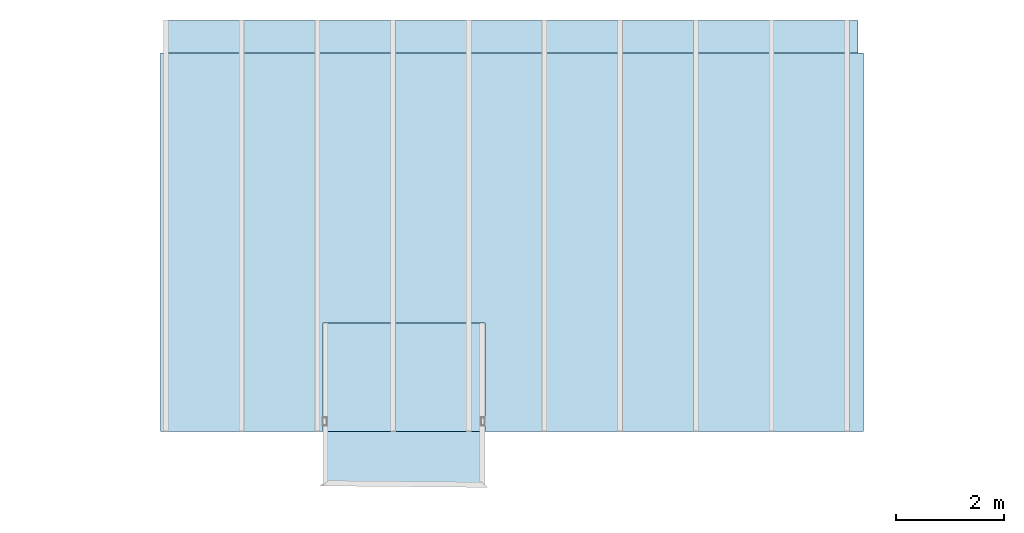
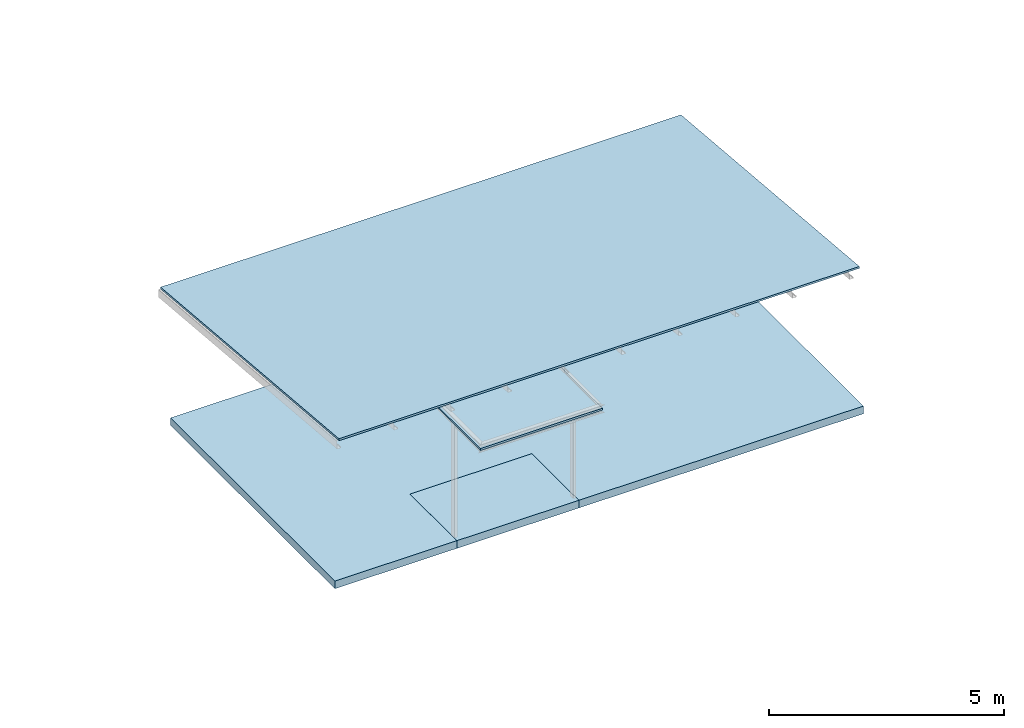
# One storey, part 8 of 8: 4 slabs.
"""IFC4 building model written with IfcOpenShell, lengths in metres."""

from ifc_helpers import new_model, si_unit, frame, origin_with_axes, origin_2d_with_axis, place, context, subcontext, project, spatial, indexed_curve, outline, extrude, material, layer, layer_set, layer_usage, type_object, element, save


model = new_model("IFC4")

# Units and contexts
model_context = context("Model", 3, precision=1e-05, world=origin_with_axes())
plan_context = context("Plan", 2, precision=1e-05, world=origin_2d_with_axis())
body_context = subcontext(model_context, "Body", "Model", "MODEL_VIEW")
ifc_project = project(units=[si_unit("VOLUMEUNIT", "CUBIC_METRE"), si_unit("LENGTHUNIT", "METRE"), si_unit("AREAUNIT", "SQUARE_METRE")], contexts=[model_context, plan_context])

# Site, building, storey
site_placement = place(None, origin_with_axes())
site = spatial("IfcSite", under=ifc_project, at=site_placement)
building_placement = place(site_placement, origin_with_axes())
building = spatial("IfcBuilding", under=site, at=building_placement, Name="Building")
storey_placement = place(building_placement, frame((0.0, 0.0, 7.0), z_axis=(0.0, 0.0, 1.0), x_axis=(1.0, 0.0, 0.0)))
storey = spatial("IfcBuildingStorey", under=building, at=storey_placement, Name="Level 2")

# Slabs
ifc_material = material()
ifc_layer_1 = layer(ifc_material, 0.20000000298023224)
ifc_layer_set_1 = layer_set([ifc_layer_1])
ifc_layer_usage_1 = layer_usage(ifc_layer_set_1, "AXIS3", "POSITIVE", -0.20000000298023224)
slab_type_1 = type_object("IfcSlabType", Name="FLR200", PredefinedType="NOTDEFINED", material=ifc_layer_set_1)
slab_1_placement = place(storey_placement, frame((-5.999999046325684, 6.999998092651367, -7.000000208616257), z_axis=(0.0, 0.0, 1.0), x_axis=(1.0, 0.0, 0.0)))
element("IfcSlab", 1, at=slab_1_placement, inside=storey, type_object=slab_type_1, material=ifc_layer_usage_1, Name="Slab", context=body_context, shape_type="SweptSolid", body=[
    extrude(outline(indexed_curve([(0.0, 0.0), (2.384185791015625e-06, -6.999999046325684), (3.0000009536743164, -6.999998092651367), (3.000000238418579, -4.999998569488525), (6.0, -4.999997138977051), (6.000000476837158, -6.999998092651367), (13.0, -6.999998092651367), (13.000000953674316, 1.9073486328125e-06), (0.0, 0.0)])), frame((0.0, 0.0, -0.20000000298023224), z_axis=(0.0, 0.0, 1.0), x_axis=(1.0, 0.0, 0.0)), (0.0, 0.0, 1.0), 0.20000000298023224),
])
ifc_layer_usage_2 = layer_usage(ifc_layer_set_1, "AXIS3", "POSITIVE", -0.20000000298023224)
slab_2_placement = place(storey_placement, frame((-2.999998092651367, 1.1368683772161603e-13, -7.0), z_axis=(0.0, 0.0, 1.0), x_axis=(1.0, 0.0, 0.0)))
element("IfcSlab", 2, at=slab_2_placement, inside=storey, type_object=slab_type_1, material=ifc_layer_usage_2, Name="Slab", context=body_context, shape_type="SweptSolid", body=[
    extrude(outline(indexed_curve([(0.0, 0.0), (-7.152557373046875e-07, 1.9999995231628418), (2.9999990463256836, 2.0000009536743164), (2.999999523162842, 0.0), (0.0, 0.0)])), frame((0.0, 0.0, -0.20000000298023224), z_axis=(0.0, 0.0, 1.0), x_axis=(1.0, 0.0, 0.0)), (0.0, 0.0, 1.0), 0.20000000298023224),
])
ifc_layer_2 = layer(ifc_material, 0.05000000074505806)
ifc_layer_set_2 = layer_set([ifc_layer_2])
ifc_layer_usage_3 = layer_usage(ifc_layer_set_2, "AXIS3", "POSITIVE", -0.20000000298023224)
slab_type_2 = type_object("IfcSlabType", Name="FLR50", PredefinedType="NOTDEFINED", material=ifc_layer_set_2)
slab_3_placement = place(storey_placement, frame((-5.999998092651367, -9.5367431640625e-07, -3.1841320991516113), z_axis=(0.0, 0.08715569813123347, 0.9961947019951759), x_axis=(1.0, 0.0, 0.0)))
element("IfcSlab", 3, at=slab_3_placement, inside=storey, type_object=slab_type_2, material=ifc_layer_usage_3, Name="Slab", context=body_context, shape_type="SweptSolid", body=[
    extrude(outline(indexed_curve([(12.89999771118164, 9.573030455107872e-07), (12.89999771118164, 7.629031141588975), (0.09999990463256836, 7.6290301842717785), (0.09999942779541016, -1.4229920800009608e-11), (12.89999771118164, 9.573030455107872e-07)])), frame((0.0, 0.017497731372714043, -0.20000000298023224), z_axis=(0.0, 0.0, 1.0), x_axis=(1.0, 0.0, 0.0)), (0.0, -0.08715573698282242, 0.9961947202682495), 0.05019099245034111),
])
ifc_layer_usage_4 = layer_usage(ifc_layer_set_2, "AXIS3", "POSITIVE", -0.05000000074505806)
slab_4_placement = place(storey_placement, frame((-2.999998092651367, 1.1368683772161603e-13, -4.0), z_axis=(0.0, 0.0, 1.0), x_axis=(1.0, 0.0, 0.0)))
element("IfcSlab", 4, at=slab_4_placement, inside=storey, type_object=slab_type_2, material=ifc_layer_usage_4, Name="Slab", context=body_context, shape_type="SweptSolid", body=[
    extrude(outline(indexed_curve([(2.999999523162842, -1.0), (2.9999990463256836, 2.0000009536743164), (-7.152557373046875e-07, 1.9999995231628418), (0.0, -1.0), (2.999999523162842, -1.0)])), frame((0.0, 0.0, -0.05000000074505806), z_axis=(0.0, 0.0, 1.0), x_axis=(1.0, 0.0, 0.0)), (0.0, 0.0, 1.0), 0.05000000074505806),
])

save(model, "model.ifc")
